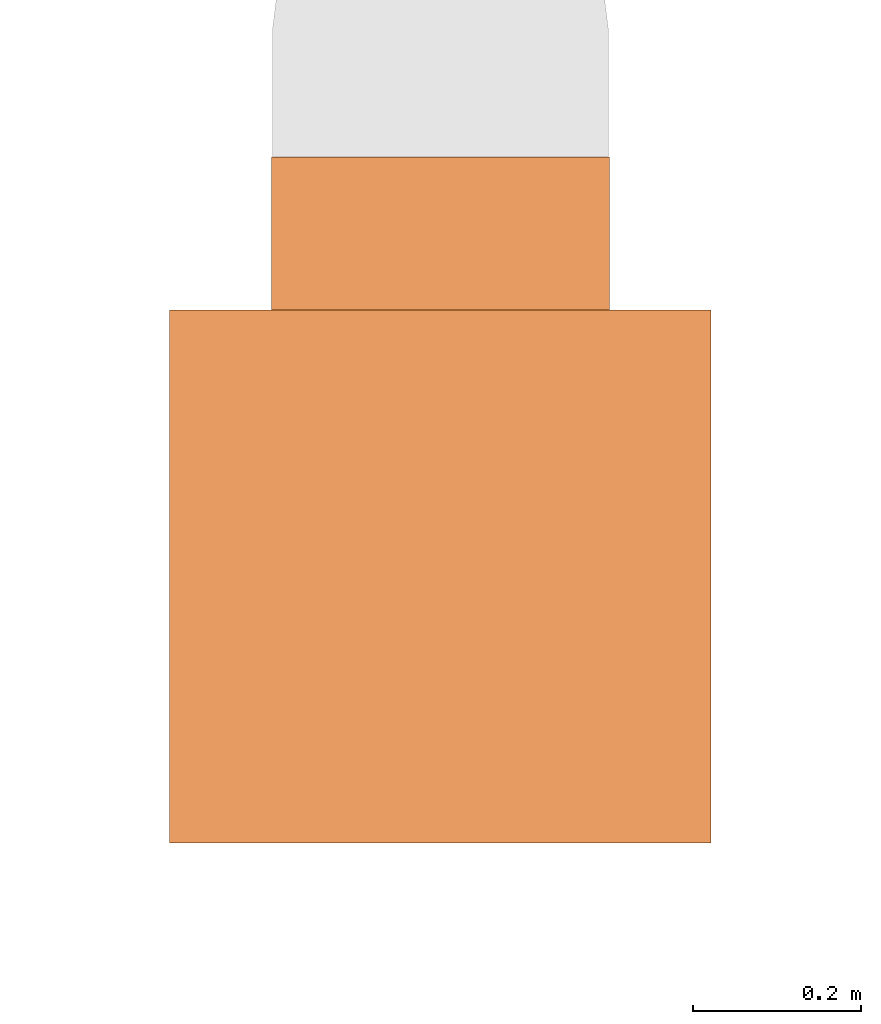
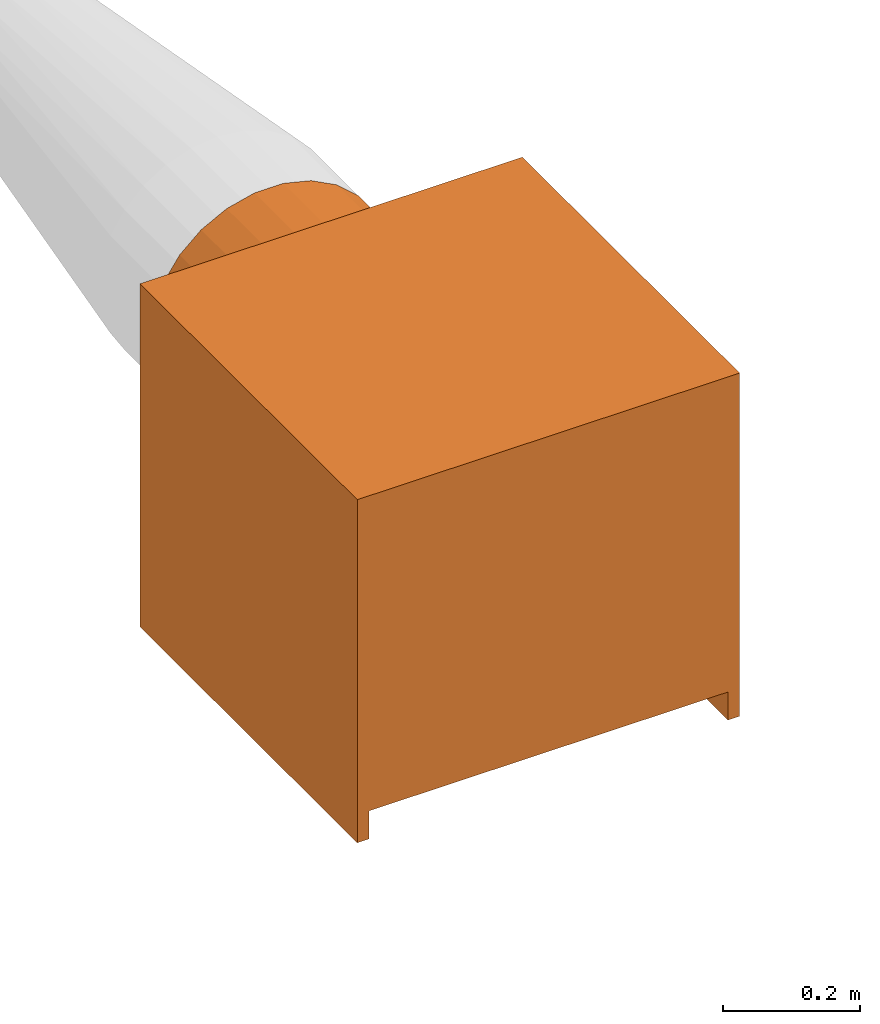
# One storey, part 6 of 6: 1 proxy.
"""IFC2X3 building model written with IfcOpenShell, lengths in metres."""

from ifc_helpers import new_model, entity, si_unit, converted_unit, derived_unit, direction, frame, origin, place, context, subcontext, project, spatial, faceted_brep, source, transform, mapped, type_object, type_shapes, element, save


model = new_model("IFC2X3")

# Units and contexts
model_context = context("Model", 3, precision=1e-05, world=origin(), true_north=direction((6.12303176911189e-17, 1.0)))
body_context = subcontext(model_context, "Body", "Model", "MODEL_VIEW")
ifc_project = project(units=[si_unit("LENGTHUNIT", "METRE"), si_unit("AREAUNIT", "SQUARE_METRE"), si_unit("VOLUMEUNIT", "CUBIC_METRE"), converted_unit("PLANEANGLEUNIT", "DEGREE", entity("IfcRatioMeasure", 0.0174532925199433), si_unit("PLANEANGLEUNIT", "RADIAN"), dimensions=[0, 0, 0, 0, 0, 0, 0]), si_unit("MASSUNIT", "GRAM", prefix="KILO"), derived_unit("MASSDENSITYUNIT", [(si_unit("MASSUNIT", "GRAM", prefix="KILO"), 1), (si_unit("LENGTHUNIT", "METRE"), -3)]), si_unit("TIMEUNIT", "SECOND"), si_unit("FREQUENCYUNIT", "HERTZ"), si_unit("THERMODYNAMICTEMPERATUREUNIT", "DEGREE_CELSIUS"), derived_unit("THERMALTRANSMITTANCEUNIT", [(si_unit("MASSUNIT", "GRAM", prefix="KILO"), 1), (si_unit("THERMODYNAMICTEMPERATUREUNIT", "KELVIN"), -1), (si_unit("TIMEUNIT", "SECOND"), -3)]), derived_unit("VOLUMETRICFLOWRATEUNIT", [(si_unit("LENGTHUNIT", "METRE"), 3), (si_unit("TIMEUNIT", "SECOND"), -1)]), si_unit("ELECTRICCURRENTUNIT", "AMPERE"), si_unit("ELECTRICVOLTAGEUNIT", "VOLT"), si_unit("POWERUNIT", "WATT"), si_unit("FORCEUNIT", "NEWTON", prefix="KILO"), si_unit("ILLUMINANCEUNIT", "LUX"), si_unit("LUMINOUSFLUXUNIT", "LUMEN"), si_unit("LUMINOUSINTENSITYUNIT", "CANDELA"), derived_unit("USERDEFINED", [(si_unit("MASSUNIT", "GRAM", prefix="KILO"), -1), (si_unit("LENGTHUNIT", "METRE"), -2), (si_unit("TIMEUNIT", "SECOND"), 3), (si_unit("LUMINOUSFLUXUNIT", "LUMEN"), 1)]), derived_unit("LINEARVELOCITYUNIT", [(si_unit("LENGTHUNIT", "METRE"), 1), (si_unit("TIMEUNIT", "SECOND"), -1)]), si_unit("PRESSUREUNIT", "PASCAL"), derived_unit("USERDEFINED", [(si_unit("LENGTHUNIT", "METRE"), -2), (si_unit("MASSUNIT", "GRAM", prefix="KILO"), 1), (si_unit("TIMEUNIT", "SECOND"), -2)])], contexts=[model_context])

# Site, building, storey
site_placement = place(None, origin())
site = spatial("IfcSite", under=ifc_project, at=site_placement, CompositionType="ELEMENT")
building_placement = place(site_placement, origin())
building = spatial("IfcBuilding", under=site, at=building_placement, CompositionType="ELEMENT")
storey_placement = place(building_placement, origin())
storey = spatial("IfcBuildingStorey", under=building, at=storey_placement, Name="1 - RDC", CompositionType="ELEMENT", Elevation=1.94210219716249e-13)

# Proxy
building_element_proxy_type = type_object("IfcBuildingElementProxyType", Name="2200 m3h", PredefinedType="NOTDEFINED")
shared_shape = source(origin(), body_context, "Body", "Brep", [
    faceted_brep([(0.1, 0.105, 0.0913397459621559), (0.1, 0.107071067811865, 0.0929289321881348), (0.1, 0.108660254037844, 0.0950000000000003), (0.1, 0.109659258262891, 0.0974118095489751), (0.1, 0.11, 0.1), (0.1, 0.109659258262891, 0.102588190451026), (0.1, 0.108660254037844, 0.105), (0.1, 0.107071067811865, 0.107071067811866), (0.1, 0.105, 0.108660254037845), (0.1, 0.102588190451025, 0.109659258262891), (0.1, 0.0999999999999999, 0.11), (0.1, 0.0974118095489747, 0.109659258262891), (0.1, 0.0949999999999999, 0.108660254037845), (0.1, 0.0929289321881344, 0.107071067811866), (0.1, 0.0913397459621555, 0.105), (0.1, 0.0903407417371092, 0.102588190451026), (0.1, 0.0899999999999999, 0.1), (0.1, 0.0903407417371092, 0.0974118095489752), (0.1, 0.0913397459621555, 0.0950000000000004), (0.1, 0.0929289321881344, 0.0929289321881349), (0.1, 0.0949999999999998, 0.091339745962156), (0.1, 0.0974118095489746, 0.0903407417371097), (0.1, 0.0999999999999998, 0.0900000000000003), (0.1, 0.102588190451025, 0.0903407417371096), (0.0, 0.0999999999999999, 0.11), (0.0, 0.102588190451025, 0.109659258262891), (0.0, 0.105, 0.108660254037845), (0.0, 0.107071067811865, 0.107071067811866), (0.0, 0.108660254037844, 0.105), (0.0, 0.109659258262891, 0.102588190451026), (0.0, 0.11, 0.1), (0.0, 0.109659258262891, 0.0974118095489751), (0.0, 0.108660254037844, 0.0950000000000003), (0.0, 0.107071067811865, 0.0929289321881348), (0.0, 0.105, 0.0913397459621559), (0.0, 0.102588190451025, 0.0903407417371096), (0.0, 0.0999999999999998, 0.0900000000000003), (0.0, 0.0974118095489746, 0.0903407417371097), (0.0, 0.0949999999999998, 0.091339745962156), (0.0, 0.0929289321881344, 0.0929289321881349), (0.0, 0.0913397459621555, 0.0950000000000004), (0.0, 0.0903407417371092, 0.0974118095489752), (0.0, 0.0899999999999999, 0.1), (0.0, 0.0903407417371092, 0.102588190451026), (0.0, 0.0913397459621555, 0.105), (0.0, 0.0929289321881344, 0.107071067811866), (0.0, 0.0949999999999999, 0.108660254037845), (0.0, 0.0974118095489747, 0.109659258262891)], [[[0, 1, 2, 3, 4, 5, 6, 7, 8, 9, 10, 11, 12, 13, 14, 15, 16, 17, 18, 19, 20, 21, 22, 23]], [[24, 25, 26, 27, 28, 29, 30, 31, 32, 33, 34, 35, 36, 37, 38, 39, 40, 41, 42, 43, 44, 45, 46, 47]], [[41, 17, 16, 42]], [[40, 18, 17, 41]], [[20, 19, 39, 38]], [[40, 39, 19, 18]], [[21, 20, 38, 37]], [[21, 37, 36, 22]], [[35, 23, 22, 36]], [[34, 0, 23, 35]], [[2, 1, 33, 32]], [[34, 33, 1, 0]], [[3, 2, 32, 31]], [[4, 3, 31, 30]], [[29, 5, 4, 30]], [[28, 6, 5, 29]], [[8, 7, 27, 26]], [[28, 27, 7, 6]], [[9, 8, 26, 25]], [[10, 9, 25, 24]], [[11, 10, 24, 47]], [[11, 47, 46, 12]], [[15, 14, 44, 43]], [[16, 15, 43, 42]], [[13, 12, 46, 45]], [[45, 44, 14, 13]]]),
    faceted_brep([(0.624000000000002, 0.0, 0.0), (0.624000000000002, 0.634, 0.0), (0.644000000000001, 0.634, 0.0), (0.644000000000001, 0.0, 0.0), (0.0, 0.0, 0.0), (0.0, 0.634, 0.0), (0.0200000000000001, 0.634, 0.0), (0.0200000000000001, 0.0, 0.0), (0.644000000000001, 0.0, 0.610999999999998), (0.644000000000001, 0.634, 0.610999999999998), (0.0, 0.634, 0.610999999999998), (0.0, 0.0, 0.610999999999998), (0.436181014092963, 0.634, 0.524419757044626), (0.39327558229555, 0.634, 0.546938264779769), (0.472450660382392, 0.634, 0.492287654306401), (0.34622787273132, 0.634, 0.558534483693709), (0.29777212726868, 0.634, 0.558534483693709), (0.499976661156296, 0.634, 0.452409357580799), (0.517159305302637, 0.634, 0.407102448521801), (0.523000000000001, 0.634, 0.359000000000002), (0.624000000000002, 0.634, 0.0499999999999978), (0.517159305302637, 0.634, 0.3108975514782), (0.499976661156296, 0.634, 0.265590642419202), (0.472450660382392, 0.634, 0.2257123456936), (0.436181014092963, 0.634, 0.193580242955375), (0.39327558229555, 0.634, 0.171061735220232), (0.34622787273132, 0.634, 0.159465516306291), (0.29777212726868, 0.634, 0.159465516306292), (0.0200000000000001, 0.634, 0.0499999999999978), (0.121000000000001, 0.634, 0.359000000000001), (0.126840694697365, 0.634, 0.310897551478202), (0.250724417704451, 0.634, 0.171061735220232), (0.207818985907038, 0.634, 0.193580242955376), (0.171549339617609, 0.634, 0.225712345693601), (0.144023338843706, 0.634, 0.265590642419204), (0.250724417704451, 0.634, 0.546938264779768), (0.207818985907038, 0.634, 0.524419757044625), (0.171549339617609, 0.634, 0.4922876543064), (0.144023338843706, 0.634, 0.452409357580797), (0.126840694697365, 0.634, 0.407102448521799), (0.0200000000000001, 0.0, 0.0499999999999978), (0.624000000000002, 0.0, 0.0499999999999978), (0.346227872731322, 0.8155, 0.558534483693709), (0.393275582295551, 0.8155, 0.546938264779769), (0.436181014092964, 0.8155, 0.524419757044625), (0.472450660382393, 0.8155, 0.4922876543064), (0.499976661156297, 0.8155, 0.452409357580798), (0.517159305302638, 0.8155, 0.407102448521799), (0.523000000000001, 0.8155, 0.358999999999999), (0.517159305302637, 0.8155, 0.3108975514782), (0.499976661156296, 0.8155, 0.265590642419202), (0.472450660382392, 0.8155, 0.2257123456936), (0.436181014092963, 0.8155, 0.193580242955375), (0.39327558229555, 0.8155, 0.171061735220232), (0.34622787273132, 0.8155, 0.159465516306291), (0.29777212726868, 0.8155, 0.159465516306292), (0.250724417704451, 0.8155, 0.171061735220232), (0.207818985907038, 0.8155, 0.193580242955376), (0.171549339617609, 0.8155, 0.225712345693601), (0.144023338843706, 0.8155, 0.265590642419204), (0.126840694697365, 0.8155, 0.310897551478202), (0.121000000000001, 0.8155, 0.359000000000001), (0.126840694697365, 0.8155, 0.4071024485218), (0.144023338843706, 0.8155, 0.452409357580798), (0.17154933961761, 0.8155, 0.492287654306401), (0.207818985907039, 0.8155, 0.524419757044626), (0.250724417704452, 0.8155, 0.546938264779769), (0.297772127268682, 0.8155, 0.558534483693709)], [[[0, 1, 2, 3]], [[4, 5, 6, 7]], [[8, 9, 10, 11]], [[9, 12, 13]], [[12, 9, 14]], [[13, 15, 9]], [[9, 15, 16]], [[17, 14, 9]], [[18, 17, 9]], [[19, 18, 9]], [[9, 20, 19]], [[16, 10, 9]], [[2, 20, 9]], [[2, 1, 20]], [[21, 19, 20]], [[22, 21, 20]], [[22, 20, 23]], [[24, 23, 20]], [[20, 25, 24]], [[26, 25, 20]], [[20, 27, 26]], [[27, 20, 28]], [[10, 29, 28]], [[28, 29, 30]], [[27, 28, 31]], [[32, 31, 28]], [[32, 28, 33]], [[34, 33, 28]], [[28, 5, 10]], [[28, 6, 5]], [[34, 28, 30]], [[16, 35, 10]], [[36, 10, 35]], [[10, 36, 37]], [[37, 38, 10]], [[38, 39, 10]], [[39, 29, 10]], [[11, 10, 5, 4]], [[11, 4, 7, 40, 41, 0, 3, 8]], [[9, 8, 3, 2]], [[28, 20, 41, 40]], [[6, 28, 40, 7]], [[0, 41, 20, 1]], [[42, 43, 44, 45, 46, 47, 48, 49, 50, 51, 52, 53, 54, 55, 56, 57, 58, 59, 60, 61, 62, 63, 64, 65, 66, 67]], [[29, 61, 60, 30]], [[59, 34, 30, 60]], [[57, 56, 31, 32]], [[33, 58, 57, 32]], [[34, 59, 58, 33]], [[31, 56, 55, 27]], [[55, 54, 26, 27]], [[26, 54, 53, 25]], [[52, 24, 25, 53]], [[50, 49, 21, 22]], [[23, 51, 50, 22]], [[24, 52, 51, 23]], [[21, 49, 48, 19]], [[47, 18, 19, 48]], [[46, 17, 18, 47]], [[12, 44, 43, 13]], [[12, 14, 45, 44]], [[43, 42, 15, 13]], [[45, 14, 17, 46]], [[42, 67, 16, 15]], [[16, 67, 66, 35]], [[65, 36, 35, 66]], [[63, 62, 39, 38]], [[37, 64, 63, 38]], [[36, 65, 64, 37]], [[39, 62, 61, 29]]]),
])
type_shapes(building_element_proxy_type, [shared_shape])
proxy_placement = place(storey_placement, frame((5.47272147345445, -4.38751978878916, 3.6)))
element("IfcBuildingElementProxy", 1, at=proxy_placement, inside=storey, type_object=building_element_proxy_type, ObjectType="2200 m3h", context=body_context, shape_type="MappedRepresentation", body=[
    mapped(shared_shape, transform((0.0, 0.0, 0.0), scale=1.0)),
])

save(model, "model.ifc")
